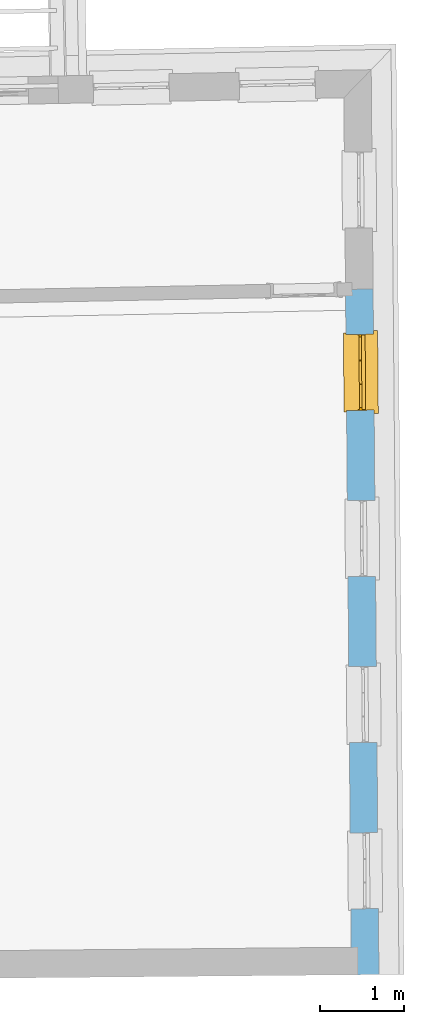
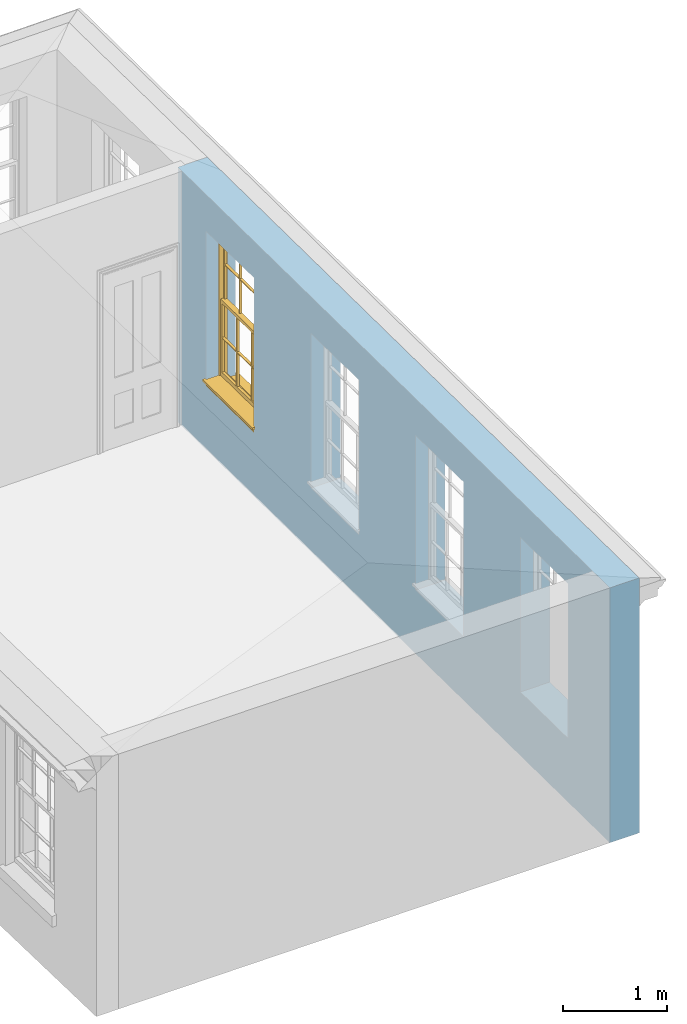
# One storey, part 5 of 11: 1 window, 4 openings, plus 1 element that does not belong to this part.
"""IFC2X3 building model written with IfcOpenShell, lengths in metres."""

from ifc_helpers import new_model, si_unit, frame, origin, place, context, subcontext, project, spatial, polyline, outline, extrude, faceted_brep, material, layer, layer_set, layer_usage, element, fill, save


model = new_model("IFC2X3")

# Units and contexts
model_context = context("Model", 3, world=origin())
body_context = subcontext(model_context, "Body", "Model", "MODEL_VIEW")
ifc_project = project(units=[si_unit("PLANEANGLEUNIT", "RADIAN"), si_unit("MASSUNIT", "GRAM", prefix="KILO"), si_unit("FORCEUNIT", "NEWTON", prefix="KILO"), si_unit("LENGTHUNIT", "METRE")], contexts=[model_context])

# Site, building, storey
site_placement = place(None, origin())
site = spatial("IfcSite", under=ifc_project, at=site_placement, CompositionType="ELEMENT")
building_placement = place(None, origin())
building = spatial("IfcBuilding", under=site, at=building_placement, Name="Building plot-11", CompositionType="ELEMENT")
storey_placement = place(None, frame((0.0, 0.0, 5.3)))
storey = spatial("IfcBuildingStorey", under=building, at=storey_placement, Name="Floor 1", CompositionType="ELEMENT", Elevation=5.3)

# Wall, openings, window
ifc_material = material(Name="Masonry")
ifc_layer = layer(ifc_material, 0.33, ventilated=False)
ifc_layer_set = layer_set([ifc_layer], Name="My Wall")
ifc_layer_usage = layer_usage(ifc_layer_set, "AXIS2", "NEGATIVE", 0.08)
wall_placement = place(storey_placement, origin())
wall = element("IfcWallStandardCase", 1, at=wall_placement, inside=storey, material=ifc_layer_usage, Name="exterior", context=body_context, shape_type="SweptSolid", body=[
    extrude(outline(polyline([(65.5837615155297, 12.2179906948306), (65.913749407515, 12.220817555827), (65.8434428524129, 20.4279108442136), (65.5134549604276, 20.4250839832172), (65.5837615155297, 12.2179906948306)])), origin(), (0.0, 0.0, 1.0), 3.0),
])
opening_1_placement = place(storey_placement, frame((0.0, 0.0, 0.75)))
element("IfcOpeningElement", 2, at=opening_1_placement, cuts=wall, Name="Opening", ObjectType="Opening", context=body_context, shape_type="SweptSolid", body=[
    extrude(outline(polyline([(65.9069848636133, 13.0104628851131), (65.8991895802596, 13.9204294963454), (65.5692016882743, 13.9176026353489), (65.576996971628, 13.0076360241167), (65.9069848636133, 13.0104628851131)])), origin(), (0.0, 0.0, 1.0), 1.82),
])
opening_2_placement = place(storey_placement, frame((0.0, 0.0, 0.75)))
element("IfcOpeningElement", 3, at=opening_2_placement, cuts=wall, Name="Opening", ObjectType="Opening", context=body_context, shape_type="SweptSolid", body=[
    extrude(outline(polyline([(65.889943615178, 14.9997385003944), (65.8821483318243, 15.9097051116266), (65.552160439839, 15.9068782506302), (65.5599557231927, 14.996911639398), (65.889943615178, 14.9997385003944)])), origin(), (0.0, 0.0, 1.0), 1.82),
])
opening_3_placement = place(storey_placement, frame((0.0, 0.0, 0.75)))
element("IfcOpeningElement", 4, at=opening_3_placement, cuts=wall, Name="Opening", ObjectType="Opening", context=body_context, shape_type="SweptSolid", body=[
    extrude(outline(polyline([(65.8729023667427, 16.9890141156756), (65.865107083389, 17.8989807269079), (65.5351191914037, 17.8961538659114), (65.5429144747574, 16.9861872546792), (65.8729023667427, 16.9890141156756)])), origin(), (0.0, 0.0, 1.0), 1.82),
])
opening_4_placement = place(storey_placement, frame((0.0, 0.0, 0.75)))
opening_4 = element("IfcOpeningElement", 5, at=opening_4_placement, cuts=wall, Name="Opening", ObjectType="Opening", context=body_context, shape_type="SweptSolid", body=[
    extrude(outline(polyline([(65.8558611183074, 18.9782897309569), (65.8480658349537, 19.8882563421891), (65.5180779429683, 19.8854294811927), (65.5258732263221, 18.9754628699605), (65.8558611183074, 18.9782897309569)])), origin(), (0.0, 0.0, 1.0), 1.82),
])
window_placement = place(storey_placement, frame((65.6058702910458, 18.976148169596, 0.75), z_axis=(0.0, 0.0, 1.0), x_axis=(-0.00779528335375801, 0.90996661123221, 0.0)))
window = element("IfcWindow", 6, at=window_placement, inside=storey, Name="bedroom outside window", OverallHeight=1.82, OverallWidth=0.91, context=body_context, shape_type="Brep", held_by="IfcProductRepresentation", body=[
    faceted_brep([(0.033125, -0.105, 0.975209), (0.01, -0.105, 0.975209), (0.033125, -0.105, 1.376042), (0.876875, -0.105, 0.975209), (0.876875, -0.105, 1.376042), (0.9, -0.105, 0.975209), (0.876875, -0.105, 1.386042), (0.876875, -0.105, 1.786875), (0.9, -0.105, 1.81), (0.033125, -0.105, 1.786875), (0.033125, -0.105, 1.386042), (0.01, -0.105, 1.81), (0.876875, -0.135, 1.376042), (0.876875, -0.135, 0.975209), (0.9, -0.135, 0.937083), (0.033125, -0.135, 1.786875), (0.01, -0.135, 1.81), (0.033125, -0.135, 1.386042), (0.01, -0.135, 0.937083), (0.033125, -0.135, 0.975209), (0.033125, -0.135, 1.376042), (0.876875, -0.135, 1.786875), (0.876875, -0.135, 1.386042), (0.9, -0.135, 1.81), (0.033125, -0.105, 0.937083), (0.01, -0.105, 0.937083), (0.033125, -0.105, 0.53625), (0.876875, -0.105, 0.937083), (0.876875, -0.105, 0.53625), (0.9, -0.105, 0.937083), (0.876875, -0.105, 0.52625), (0.876875, -0.105, 0.125417), (0.9, -0.105, 0.077167), (0.033125, -0.105, 0.125417), (0.033125, -0.105, 0.52625), (0.01, -0.105, 0.077167), (-0.0425, -0.25, 0.01), (-0.0425, -0.3, 0.001667), (0.0, -0.25, 0.01), (0.9525, -0.25, 0.01), (0.91, -0.25, 0.01), (0.9525, -0.3, 0.001667), (-0.02, 0.08, 0.077167), (0.0, 0.08, 0.077167), (-0.02, 0.11, 0.077167), (0.0, -0.06, 0.077167), (0.01, -0.06, 0.077167), (0.91, -0.06, 0.077167), (0.91, 0.08, 0.077167), (0.9, -0.06, 0.077167), (0.93, 0.08, 0.077167), (0.93, 0.11, 0.077167), (0.01, -0.075, 0.975209), (0.9, -0.075, 0.975209), (0.876875, -0.075, 0.125417), (0.876875, -0.075, 0.52625), (0.9, -0.075, 0.077167), (0.876875, -0.075, 0.53625), (0.876875, -0.075, 0.937083), (0.033125, -0.075, 0.125417), (0.01, -0.075, 0.077167), (0.033125, -0.075, 0.52625), (0.033125, -0.075, 0.937083), (0.033125, -0.075, 0.53625), (-0.02, 0.08, 0.052167), (-0.02, 0.11, 0.052167), (0.93, 0.11, 0.052167), (0.93, 0.08, 0.052167), (0.91, 0.08, 0.052167), (0.0, 0.08, 0.052167), (0.91, -0.15, 0.026667), (0.0, -0.15, 0.026667), (-0.0425, -0.3, -0.123333), (0.9525, -0.3, -0.123333), (-0.0425, -0.25, -0.123333), (0.9525, -0.25, -0.123333), (0.01, -0.06, 1.81), (0.9, -0.06, 1.81), (0.0, -0.06, 1.82), (0.91, -0.06, 1.82), (0.01, -0.15, 0.077167), (0.9, -0.15, 0.077167), (0.592292, -0.105, 0.125417), (0.592292, -0.075, 0.125417), (0.317708, -0.075, 0.125417), (0.317708, -0.105, 0.125417), (0.592292, -0.105, 0.53625), (0.317708, -0.105, 0.53625), (0.317708, -0.105, 0.52625), (0.592292, -0.105, 0.52625), (0.592292, -0.075, 0.53625), (0.317708, -0.075, 0.53625), (0.592292, -0.135, 1.386042), (0.592292, -0.105, 1.386042), (0.317708, -0.105, 1.386042), (0.317708, -0.135, 1.386042), (0.317708, -0.135, 1.376042), (0.592292, -0.135, 1.376042), (0.317708, -0.105, 1.376042), (0.592292, -0.105, 1.376042), (0.602292, -0.135, 1.376042), (0.592292, -0.135, 0.975209), (0.602292, -0.135, 0.975209), (0.602292, -0.105, 0.975209), (0.592292, -0.105, 0.975209), (0.602292, -0.105, 1.376042), (0.602292, -0.075, 0.53625), (0.602292, -0.105, 0.53625), (0.317708, -0.075, 0.52625), (0.307708, -0.075, 0.125417), (0.307708, -0.075, 0.52625), (0.602292, -0.075, 0.52625), (0.602292, -0.075, 0.125417), (0.592292, -0.075, 0.52625), (0.307708, -0.075, 0.53625), (0.317708, -0.075, 0.937083), (0.307708, -0.075, 0.937083), (0.602292, -0.075, 0.937083), (0.592292, -0.075, 0.937083), (0.307708, -0.105, 0.52625), (0.307708, -0.105, 0.125417), (0.307708, -0.105, 0.53625), (0.307708, -0.105, 0.937083), (0.592292, -0.105, 0.937083), (0.317708, -0.105, 0.937083), (0.602292, -0.105, 0.937083), (0.602292, -0.105, 0.52625), (0.602292, -0.105, 0.125417), (0.307708, -0.135, 1.386042), (0.307708, -0.135, 1.376042), (0.307708, -0.135, 0.975209), (0.317708, -0.135, 0.975209), (0.317708, -0.135, 1.786875), (0.307708, -0.135, 1.786875), (0.602292, -0.135, 1.786875), (0.592292, -0.135, 1.786875), (0.602292, -0.135, 1.386042), (0.602292, -0.105, 1.386042), (0.307708, -0.105, 1.386042), (0.307708, -0.105, 1.786875), (0.317708, -0.105, 1.786875), (0.592292, -0.105, 1.786875), (0.602292, -0.105, 1.786875), (0.307708, -0.105, 1.376042), (0.317708, -0.105, 0.975209), (0.307708, -0.105, 0.975209), (0.91, -0.15, 1.82), (0.9, -0.15, 1.81), (0.01, -0.15, 1.81), (0.0, -0.15, 1.82), (0.91, -0.25, 0.0), (0.0, -0.25, 0.0), (0.91, 0.08, 0.0), (0.0, 0.08, 0.0)], [[[0, 1, 2]], [[3, 4, 5]], [[6, 7, 8]], [[9, 10, 11]], [[12, 13, 14]], [[15, 16, 17]], [[18, 19, 20]], [[21, 22, 23]], [[24, 25, 26]], [[27, 28, 29]], [[30, 31, 32]], [[33, 34, 35]], [[14, 27, 29]], [[25, 24, 18]], [[36, 37, 38]], [[39, 40, 41]], [[42, 43, 44]], [[45, 46, 43]], [[47, 48, 49]], [[50, 51, 48]], [[1, 0, 52]], [[5, 53, 3]], [[54, 55, 56]], [[57, 58, 53]], [[59, 60, 61]], [[62, 63, 52]], [[48, 43, 46, 49]], [[51, 44, 43, 48]], [[64, 42, 44, 65]], [[65, 44, 51, 66]], [[66, 51, 50, 67]], [[65, 66, 68, 69]], [[60, 56, 49, 46]], [[70, 71, 38, 40]], [[37, 41, 40, 38]], [[37, 72, 73, 41]], [[74, 75, 73, 72]], [[8, 11, 76, 77]], [[76, 78, 79, 77]], [[32, 35, 80, 81]], [[81, 80, 71, 70]], [[82, 83, 84, 85]], [[86, 87, 88, 89]], [[86, 90, 91, 87]], [[92, 93, 94, 95]], [[92, 95, 96, 97]], [[96, 98, 99, 97]], [[100, 97, 101, 102]], [[103, 104, 99, 105]], [[97, 99, 104, 101]], [[102, 103, 105, 100]], [[28, 57, 106, 107]], [[108, 84, 109, 110]], [[111, 112, 83, 113]], [[114, 110, 61, 63]], [[90, 113, 108, 91]], [[115, 91, 114, 116]], [[117, 106, 90, 118]], [[111, 106, 57, 55]], [[119, 110, 109, 120]], [[34, 61, 110, 119]], [[89, 113, 83, 82]], [[88, 108, 113, 89]], [[85, 84, 108, 88]], [[121, 114, 63, 26]], [[122, 116, 114, 121]], [[123, 118, 90, 86]], [[87, 91, 115, 124]], [[107, 106, 117, 125]], [[126, 111, 55, 30]], [[127, 112, 111, 126]], [[126, 30, 28, 107]], [[88, 119, 120, 85]], [[126, 89, 82, 127]], [[125, 123, 86, 107]], [[121, 26, 34, 119]], [[124, 122, 121, 87]], [[128, 17, 20, 129]], [[96, 129, 130, 131]], [[132, 133, 128, 95]], [[134, 135, 92, 136]], [[100, 12, 22, 136]], [[137, 6, 4, 105]], [[94, 138, 139, 140]], [[137, 93, 141, 142]], [[99, 98, 94, 93]], [[143, 2, 10, 138]], [[144, 145, 143, 98]], [[129, 143, 145, 130]], [[20, 2, 143, 129]], [[131, 144, 98, 96]], [[128, 138, 10, 17]], [[133, 139, 138, 128]], [[135, 141, 93, 92]], [[95, 94, 140, 132]], [[22, 6, 137, 136]], [[136, 137, 142, 134]], [[100, 105, 4, 12]], [[107, 86, 89, 126]], [[106, 111, 113, 90]], [[91, 108, 110, 114]], [[87, 121, 119, 88]], [[97, 100, 136, 92]], [[129, 96, 95, 128]], [[98, 143, 138, 94]], [[105, 99, 93, 137]], [[131, 101, 104, 144]], [[124, 115, 118, 123]], [[132, 140, 141, 135]], [[120, 109, 59, 33]], [[15, 9, 139, 133]], [[134, 142, 7, 21]], [[31, 54, 112, 127]], [[36, 74, 72, 37]], [[39, 41, 73, 75]], [[18, 14, 101, 131]], [[23, 16, 132, 135]], [[83, 56, 60, 84]], [[52, 53, 118, 115]], [[53, 52, 144, 104]], [[11, 8, 141, 140]], [[14, 18, 124, 123]], [[2, 1, 11, 10]], [[8, 5, 4, 6]], [[57, 53, 56, 55]], [[60, 52, 63, 61]], [[26, 25, 35, 34]], [[32, 29, 28, 30]], [[14, 23, 22, 12]], [[18, 20, 17, 16]], [[19, 0, 2, 20]], [[17, 10, 9, 15]], [[12, 4, 3, 13]], [[21, 7, 6, 22]], [[27, 58, 57, 28]], [[30, 55, 54, 31]], [[33, 59, 61, 34]], [[26, 63, 62, 24]], [[5, 8, 77, 53]], [[76, 11, 1, 52]], [[46, 45, 78, 76]], [[49, 77, 79, 47]], [[70, 146, 147, 81]], [[71, 80, 148, 149]], [[19, 130, 145, 0]], [[102, 13, 3, 103]], [[116, 122, 24, 62]], [[29, 32, 81, 14]], [[80, 35, 25, 18]], [[60, 46, 76, 52]], [[77, 49, 56, 53]], [[23, 14, 81, 147]], [[16, 148, 80, 18]], [[35, 85, 120]], [[120, 33, 35]], [[127, 82, 32]], [[32, 31, 127]], [[32, 82, 85, 35]], [[102, 101, 14]], [[14, 13, 102]], [[18, 131, 130]], [[130, 19, 18]], [[134, 21, 23]], [[23, 135, 134]], [[16, 15, 133]], [[133, 132, 16]], [[11, 140, 139]], [[139, 9, 11]], [[142, 141, 8]], [[8, 7, 142]], [[23, 147, 148, 16]], [[146, 149, 148, 147]], [[52, 115, 116]], [[116, 62, 52]], [[118, 53, 117]], [[58, 117, 53]], [[27, 125, 117, 58]], [[56, 83, 112]], [[112, 54, 56]], [[109, 84, 60]], [[60, 59, 109]], [[125, 27, 14]], [[14, 123, 125]], [[122, 124, 18]], [[18, 24, 122]], [[145, 144, 52]], [[52, 0, 145]], [[103, 3, 53]], [[53, 104, 103]], [[79, 78, 149, 146]], [[78, 45, 71, 149]], [[146, 70, 47, 79]], [[150, 75, 74, 151]], [[68, 66, 67]], [[48, 68, 67, 50]], [[69, 64, 65]], [[42, 64, 69, 43]], [[69, 68, 152, 153]], [[70, 68, 48, 47]], [[150, 152, 68, 70]], [[43, 69, 71, 45]], [[69, 153, 151, 71]], [[152, 150, 151, 153]], [[38, 151, 74, 36]], [[71, 151, 38]], [[39, 75, 150, 40]], [[40, 150, 70]]]),
])
fill(opening_4, window)

save(model, "model.ifc")
